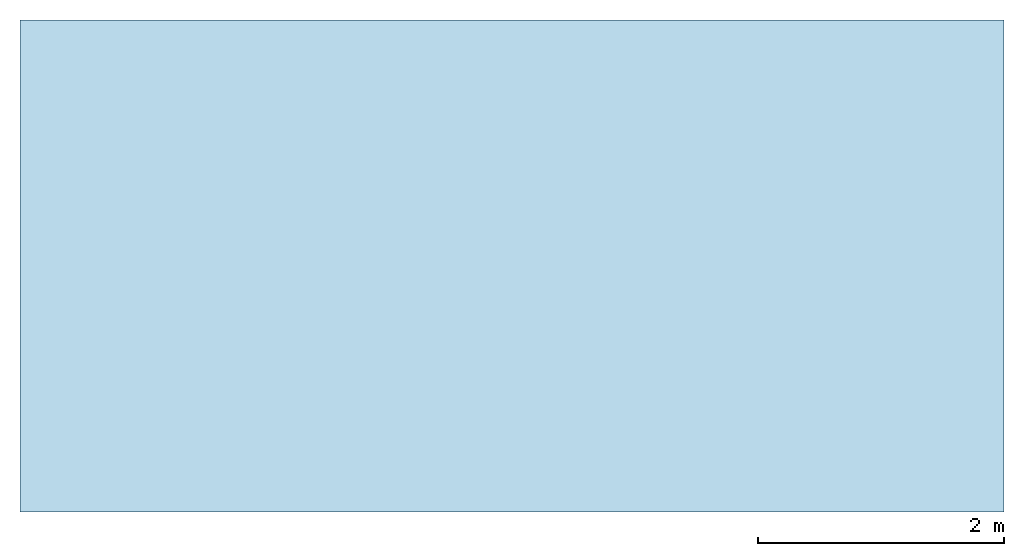
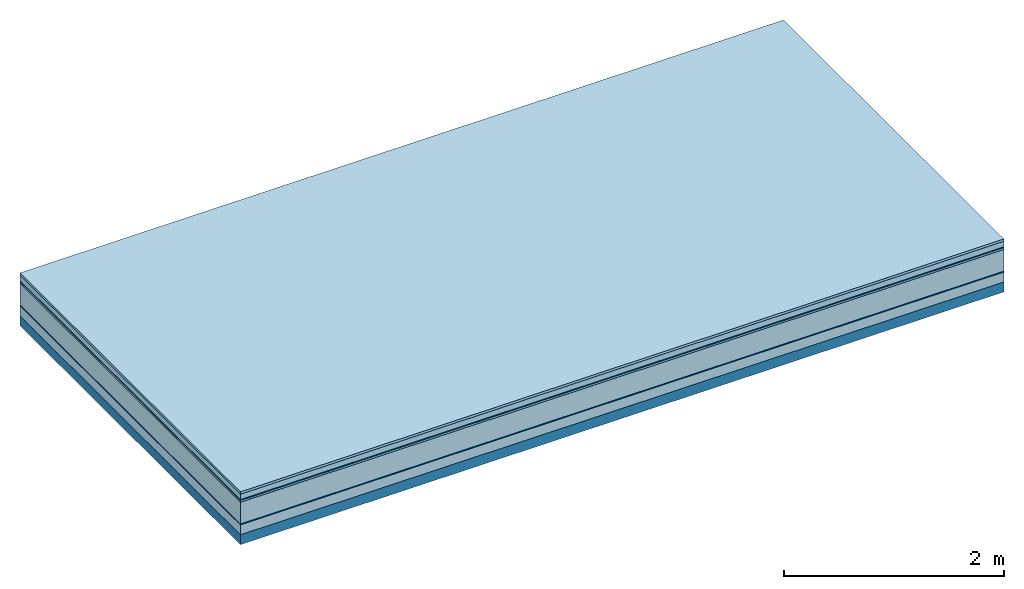
# One storey: 7 plates, 1 member, 1 element without a shape of its own.
"""IFC4 building model written with IfcOpenShell, lengths in metres."""

from ifc_helpers import new_model, si_unit, derived_unit, direction, frame, frame_2d, origin, origin_with_axes, place, context, project, spatial, rectangle, extrude, material, layer, layer_set, type_object, element, aggregate, save


model = new_model("IFC4")

# Units and contexts
plan_context = context("Plan", 3, precision=1e-05, world=origin(), true_north=direction((0.0, 1.0)))
model_context = context("Model", 3, precision=1e-05, world=origin(), true_north=direction((0.0, 1.0)))
ifc_project = project(units=[si_unit("LENGTHUNIT", "METRE"), derived_unit("SOUNDPRESSUREUNIT", [(si_unit("PRESSUREUNIT", "PASCAL", prefix="MICRO"), 0)]), si_unit("ENERGYUNIT", "JOULE", prefix="MEGA"), si_unit("MASSUNIT", "GRAM", prefix="KILO"), derived_unit("THERMALTRANSMITTANCEUNIT", [(si_unit("POWERUNIT", "WATT"), 1), (si_unit("AREAUNIT", "SQUARE_METRE"), -1), (si_unit("THERMODYNAMICTEMPERATUREUNIT", "KELVIN"), -1)]), derived_unit("AREADENSITYUNIT", [(si_unit("MASSUNIT", "GRAM", prefix="KILO"), 1), (si_unit("AREAUNIT", "SQUARE_METRE"), -1)]), derived_unit("USERDEFINED", [(si_unit("ENERGYUNIT", "JOULE", prefix="MEGA"), 1), (si_unit("AREAUNIT", "SQUARE_METRE"), -1)])], contexts=[plan_context, model_context])

# Site, building, storey
site = spatial("IfcSite", under=ifc_project)
building_placement = place(None, origin())
building = spatial("IfcBuilding", under=site, at=building_placement)
storey_placement = place(building_placement, origin())
storey = spatial("IfcBuildingStorey", under=building, at=storey_placement)

# Slab, member, plates
ifc_material_1 = material(Category="07.009")
ifc_layer_1 = layer(ifc_material_1, 0.026, Name="Use and protection layer 3")
ifc_material_2 = material(Category="07.011")
ifc_layer_2 = layer(ifc_material_2, 0.06, Name="Use and protection layer 2")
ifc_material_3 = material(Name="Protective layer + Fire protection cover RF1", Category="09.007")
ifc_layer_3 = layer(ifc_material_3, 0.01, Name="Use and protection layer 1")
ifc_material_4 = material(Name="Bituminous", Category="09.003")
ifc_layer_4 = layer(ifc_material_4, 0.02, Name="Seal")
ifc_material_5 = material(Name="Mineral wool", Category="10.008")
ifc_layer_5 = layer(ifc_material_5, 0.24, Name="Exterior insulation layer 1")
ifc_material_6 = material(Name="Vapor-permeable barrier", Category="09.006")
ifc_layer_6 = layer(ifc_material_6, 0.01, Name="layer / temporary roof")
ifc_material_7 = material(Category="01.002")
ifc_layer_7 = layer(ifc_material_7, 0.11, Name="above 1st layer")
ifc_material_8 = material(Name="Rigid, of the art")
ifc_layer_8 = layer(ifc_material_8, 0.0, Name="Bond")
ifc_layer_9 = layer(None, 0.11, Name="Support")
ifc_layer_set = layer_set([ifc_layer_1, ifc_layer_2, ifc_layer_3, ifc_layer_4, ifc_layer_5, ifc_layer_6, ifc_layer_7, ifc_layer_8, ifc_layer_9])
slab_type = type_object("IfcSlabType", Name="F0080", PredefinedType="NOTDEFINED", material=ifc_layer_set)
slab_placement = place(None, frame((0.0, 0.0, 0.0), z_axis=(0.0, 0.0, -1.0), x_axis=(1.0, 0.0, 0.0)))
slab = element("IfcSlab", 1, at=slab_placement, inside=storey, type_object=slab_type, material=ifc_layer_set, Name="Slab #1")
ifc_material_9 = material(Name="Solid timber panel")
member_placement = place(slab_placement, origin())
member = element("IfcMember", 2, at=member_placement, material=ifc_material_9, Name="Support", context=plan_context, shape_type="SweptSolid", body=[
    extrude(rectangle(XDim=1.0, YDim=0.11, at=frame_2d((0.5, 0.055), x_axis=(1.0, 0.0))), frame((0.0, 4.0, 0.476), z_axis=(0.0, -1.0, 0.0), x_axis=(1.0, 0.0, 0.0)), (0.0, 0.0, 1.0), 4.0),
    extrude(rectangle(XDim=1.0, YDim=0.11, at=frame_2d((0.5, 0.055), x_axis=(1.0, 0.0))), frame((1.0, 4.0, 0.476), z_axis=(0.0, -1.0, 0.0), x_axis=(1.0, 0.0, 0.0)), (0.0, 0.0, 1.0), 4.0),
    extrude(rectangle(XDim=1.0, YDim=0.11, at=frame_2d((0.5, 0.055), x_axis=(1.0, 0.0))), frame((2.0, 4.0, 0.476), z_axis=(0.0, -1.0, 0.0), x_axis=(1.0, 0.0, 0.0)), (0.0, 0.0, 1.0), 4.0),
    extrude(rectangle(XDim=1.0, YDim=0.11, at=frame_2d((0.5, 0.055), x_axis=(1.0, 0.0))), frame((3.0, 4.0, 0.476), z_axis=(0.0, -1.0, 0.0), x_axis=(1.0, 0.0, 0.0)), (0.0, 0.0, 1.0), 4.0),
    extrude(rectangle(XDim=1.0, YDim=0.11, at=frame_2d((0.5, 0.055), x_axis=(1.0, 0.0))), frame((4.0, 4.0, 0.476), z_axis=(0.0, -1.0, 0.0), x_axis=(1.0, 0.0, 0.0)), (0.0, 0.0, 1.0), 4.0),
    extrude(rectangle(XDim=1.0, YDim=0.11, at=frame_2d((0.5, 0.055), x_axis=(1.0, 0.0))), frame((5.0, 4.0, 0.476), z_axis=(0.0, -1.0, 0.0), x_axis=(1.0, 0.0, 0.0)), (0.0, 0.0, 1.0), 4.0),
    extrude(rectangle(XDim=1.0, YDim=0.11, at=frame_2d((0.5, 0.055), x_axis=(1.0, 0.0))), frame((6.0, 4.0, 0.476), z_axis=(0.0, -1.0, 0.0), x_axis=(1.0, 0.0, 0.0)), (0.0, 0.0, 1.0), 4.0),
    extrude(rectangle(XDim=1.0, YDim=0.11, at=frame_2d((0.5, 0.055), x_axis=(1.0, 0.0))), frame((7.0, 4.0, 0.476), z_axis=(0.0, -1.0, 0.0), x_axis=(1.0, 0.0, 0.0)), (0.0, 0.0, 1.0), 4.0),
])
plate_1_placement = place(slab_placement, origin())
plate_1 = element("IfcPlate", 3, at=plate_1_placement, material=ifc_material_1, Name="Use and protection layer 3", context=plan_context, shape_type="SweptSolid", body=[
    extrude(rectangle(XDim=8.0, YDim=4.0, at=frame_2d((4.0, 2.0), x_axis=(1.0, 0.0))), origin_with_axes(), (0.0, 0.0, 1.0), 0.026),
])
plate_2_placement = place(slab_placement, origin())
plate_2 = element("IfcPlate", 4, at=plate_2_placement, material=ifc_material_2, Name="Use and protection layer 2", context=plan_context, shape_type="SweptSolid", body=[
    extrude(rectangle(XDim=8.0, YDim=4.0, at=frame_2d((4.0, 2.0), x_axis=(1.0, 0.0))), frame((0.0, 0.0, 0.026), z_axis=(0.0, 0.0, 1.0), x_axis=(1.0, 0.0, 0.0)), (0.0, 0.0, 1.0), 0.06),
])
plate_3_placement = place(slab_placement, origin())
plate_3 = element("IfcPlate", 5, at=plate_3_placement, material=ifc_material_3, Name="Use and protection layer 1", context=plan_context, shape_type="SweptSolid", body=[
    extrude(rectangle(XDim=8.0, YDim=4.0, at=frame_2d((4.0, 2.0), x_axis=(1.0, 0.0))), frame((0.0, 0.0, 0.086), z_axis=(0.0, 0.0, 1.0), x_axis=(1.0, 0.0, 0.0)), (0.0, 0.0, 1.0), 0.01),
])
plate_4_placement = place(slab_placement, origin())
plate_4 = element("IfcPlate", 6, at=plate_4_placement, material=ifc_material_4, Name="Seal", context=plan_context, shape_type="SweptSolid", body=[
    extrude(rectangle(XDim=8.0, YDim=4.0, at=frame_2d((4.0, 2.0), x_axis=(1.0, 0.0))), frame((0.0, 0.0, 0.096), z_axis=(0.0, 0.0, 1.0), x_axis=(1.0, 0.0, 0.0)), (0.0, 0.0, 1.0), 0.02),
])
plate_5_placement = place(slab_placement, origin())
plate_5 = element("IfcPlate", 7, at=plate_5_placement, material=ifc_material_5, Name="Exterior insulation layer 1", context=plan_context, shape_type="SweptSolid", body=[
    extrude(rectangle(XDim=8.0, YDim=4.0, at=frame_2d((4.0, 2.0), x_axis=(1.0, 0.0))), frame((0.0, 0.0, 0.116), z_axis=(0.0, 0.0, 1.0), x_axis=(1.0, 0.0, 0.0)), (0.0, 0.0, 1.0), 0.24),
])
plate_6_placement = place(slab_placement, origin())
plate_6 = element("IfcPlate", 8, at=plate_6_placement, material=ifc_material_6, Name="layer / temporary roof", context=plan_context, shape_type="SweptSolid", body=[
    extrude(rectangle(XDim=8.0, YDim=4.0, at=frame_2d((4.0, 2.0), x_axis=(1.0, 0.0))), frame((0.0, 0.0, 0.356), z_axis=(0.0, 0.0, 1.0), x_axis=(1.0, 0.0, 0.0)), (0.0, 0.0, 1.0), 0.01),
])
plate_7_placement = place(slab_placement, origin())
plate_7 = element("IfcPlate", 9, at=plate_7_placement, material=ifc_material_7, Name="above 1st layer", context=plan_context, shape_type="SweptSolid", body=[
    extrude(rectangle(XDim=8.0, YDim=4.0, at=frame_2d((4.0, 2.0), x_axis=(1.0, 0.0))), frame((0.0, 0.0, 0.366), z_axis=(0.0, 0.0, 1.0), x_axis=(1.0, 0.0, 0.0)), (0.0, 0.0, 1.0), 0.11),
])
aggregate(slab, [plate_1, plate_2, plate_3, plate_4, plate_5, plate_6, plate_7, member])

save(model, "model.ifc")
